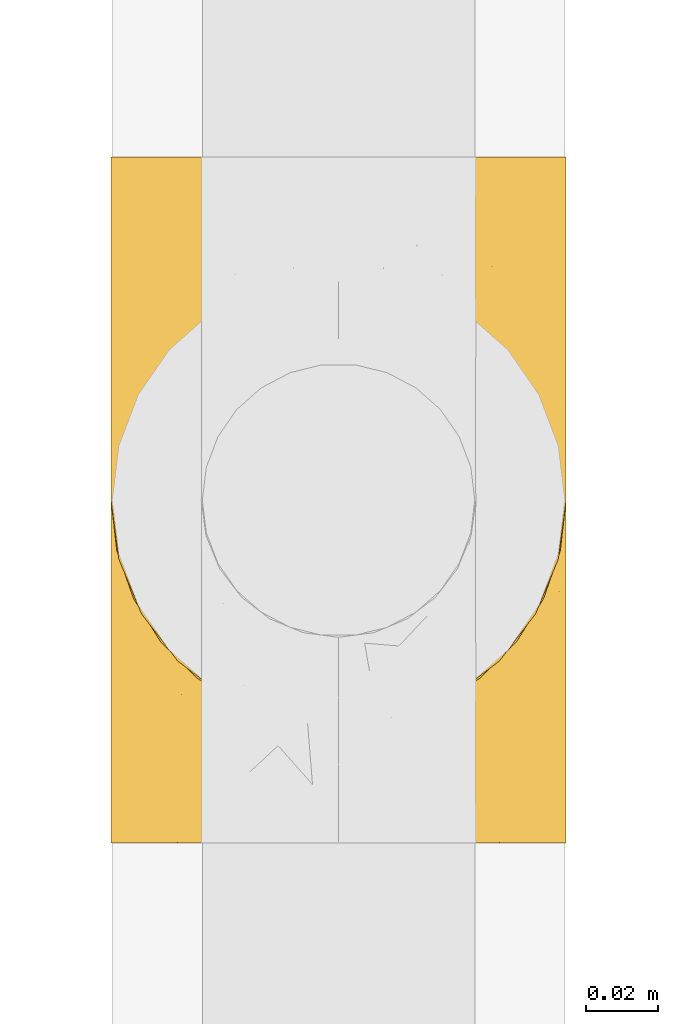
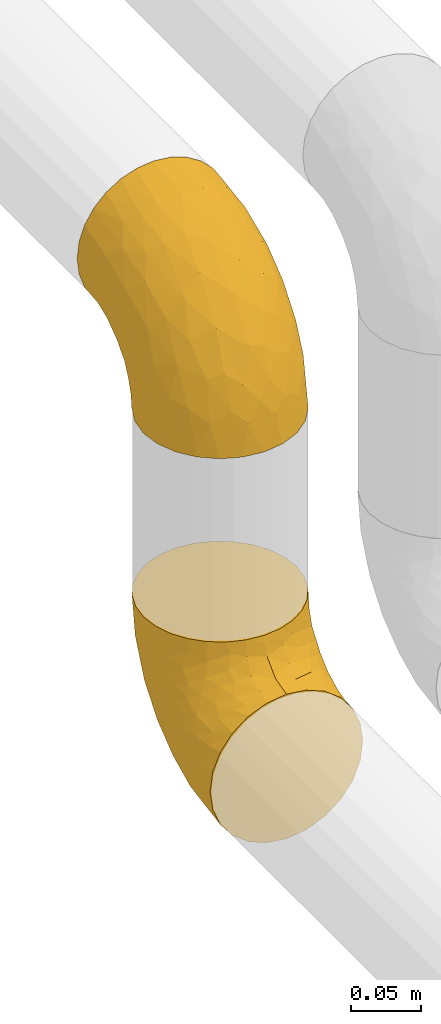
# One storey, part 102 of 827: 2 coverings.
"""IFC2X3 building model written with IfcOpenShell, lengths in millimetres."""

from ifc_helpers import new_model, entity, si_unit, converted_unit, derived_unit, direction, frame, origin, place, context, subcontext, project, spatial, faceted_brep, element, save


model = new_model("IFC2X3")

# Units and contexts
model_context = context("Model", 3, precision=0.01, world=origin(), true_north=direction((6.12303176911189e-17, 1.0)))
body_context = subcontext(model_context, "Body", "Model", "MODEL_VIEW")
ifc_project = project(units=[si_unit("LENGTHUNIT", "METRE", prefix="MILLI"), si_unit("AREAUNIT", "SQUARE_METRE"), si_unit("VOLUMEUNIT", "CUBIC_METRE"), converted_unit("PLANEANGLEUNIT", "DEGREE", entity("IfcRatioMeasure", 0.0174532925199433), si_unit("PLANEANGLEUNIT", "RADIAN"), dimensions=[0, 0, 0, 0, 0, 0, 0]), si_unit("MASSUNIT", "GRAM", prefix="KILO"), derived_unit("MASSDENSITYUNIT", [(si_unit("MASSUNIT", "GRAM", prefix="KILO"), 1), (si_unit("LENGTHUNIT", "METRE"), -3)]), derived_unit("MOMENTOFINERTIAUNIT", [(si_unit("LENGTHUNIT", "METRE"), 4)]), si_unit("TIMEUNIT", "SECOND"), si_unit("FREQUENCYUNIT", "HERTZ"), si_unit("THERMODYNAMICTEMPERATUREUNIT", "DEGREE_CELSIUS"), derived_unit("THERMALTRANSMITTANCEUNIT", [(si_unit("MASSUNIT", "GRAM", prefix="KILO"), 1), (si_unit("THERMODYNAMICTEMPERATUREUNIT", "KELVIN"), -1), (si_unit("TIMEUNIT", "SECOND"), -3)]), derived_unit("VOLUMETRICFLOWRATEUNIT", [(si_unit("LENGTHUNIT", "METRE"), 3), (si_unit("TIMEUNIT", "SECOND"), -1)]), derived_unit("MASSFLOWRATEUNIT", [(si_unit("MASSUNIT", "GRAM", prefix="KILO"), 1), (si_unit("TIMEUNIT", "SECOND"), -1)]), derived_unit("ROTATIONALFREQUENCYUNIT", [(si_unit("TIMEUNIT", "SECOND"), -1)]), si_unit("ELECTRICCURRENTUNIT", "AMPERE"), si_unit("ELECTRICVOLTAGEUNIT", "VOLT"), si_unit("POWERUNIT", "WATT"), si_unit("FORCEUNIT", "NEWTON", prefix="KILO"), si_unit("ILLUMINANCEUNIT", "LUX"), si_unit("LUMINOUSFLUXUNIT", "LUMEN"), si_unit("LUMINOUSINTENSITYUNIT", "CANDELA"), derived_unit("USERDEFINED", [(si_unit("MASSUNIT", "GRAM", prefix="KILO"), -1), (si_unit("LENGTHUNIT", "METRE"), -2), (si_unit("TIMEUNIT", "SECOND"), 3), (si_unit("LUMINOUSFLUXUNIT", "LUMEN"), 1)]), derived_unit("LINEARVELOCITYUNIT", [(si_unit("LENGTHUNIT", "METRE"), 1), (si_unit("TIMEUNIT", "SECOND"), -1)]), si_unit("PRESSUREUNIT", "PASCAL"), derived_unit("USERDEFINED", [(si_unit("LENGTHUNIT", "METRE"), -2), (si_unit("MASSUNIT", "GRAM", prefix="KILO"), 1), (si_unit("TIMEUNIT", "SECOND"), -2)]), derived_unit("LINEARFORCEUNIT", [(si_unit("MASSUNIT", "GRAM", prefix="KILO"), 1), (si_unit("LENGTHUNIT", "METRE"), 1), (si_unit("TIMEUNIT", "SECOND"), -2), (si_unit("LENGTHUNIT", "METRE"), -1)]), derived_unit("PLANARFORCEUNIT", [(si_unit("MASSUNIT", "GRAM", prefix="KILO"), 1), (si_unit("LENGTHUNIT", "METRE"), 1), (si_unit("TIMEUNIT", "SECOND"), -2), (si_unit("LENGTHUNIT", "METRE"), -2)])], contexts=[model_context])

# Site, building, storey
site_placement = place(None, origin())
site = spatial("IfcSite", under=ifc_project, at=site_placement, CompositionType="ELEMENT")
building_placement = place(site_placement, origin())
building = spatial("IfcBuilding", under=site, at=building_placement, CompositionType="ELEMENT")
storey_placement = place(building_placement, frame((0.0, 0.0, 28200.0)))
storey = spatial("IfcBuildingStorey", under=building, at=storey_placement, Name="08", CompositionType="ELEMENT", Elevation=28200.0)

# Coverings
covering_1_placement = place(storey_placement, frame((26598.99, 9529.11, 3035.35)))
element("IfcCovering", 1, at=covering_1_placement, inside=storey, Name=":ADSK_", ObjectType=":ADSK_", PredefinedType="INSULATION", context=body_context, shape_type="Brep", body=[
    faceted_brep([(126.11, 110.62, 159.65), (121.45, 123.95, 159.65), (113.94, 135.9, 159.65), (103.96, 145.89, 159.65), (92.0, 153.4, 159.65), (78.68, 158.06, 159.65), (64.65, 159.65, 159.65), (50.62, 158.06, 159.65), (37.29, 153.4, 159.65), (25.34, 145.89, 159.65), (15.35, 135.91, 159.65), (7.84, 123.95, 159.65), (3.18, 110.63, 159.65), (1.6, 96.6, 159.65), (3.18, 82.57, 159.65), (7.84, 69.24, 159.65), (15.35, 57.29, 159.65), (25.33, 47.3, 159.65), (37.29, 39.79, 159.65), (50.61, 35.13, 159.65), (64.65, 33.55, 159.65), (78.67, 35.13, 159.65), (92.0, 39.79, 159.65), (103.95, 47.3, 159.65), (113.94, 57.28, 159.65), (121.45, 69.24, 159.65), (126.11, 82.56, 159.65), (127.7, 96.6, 159.65), (64.65, 1.6, 127.7), (48.33, 1.6, 125.55), (33.12, 1.6, 119.25), (20.06, 1.6, 109.23), (10.04, 1.6, 96.17), (3.74, 1.6, 80.96), (3.01, 1.6, 75.35), (1.6, 1.6, 64.65), (3.74, 1.6, 48.33), (10.04, 1.6, 33.12), (20.06, 1.6, 20.06), (33.12, 1.6, 10.04), (48.33, 1.6, 3.74), (64.65, 1.6, 1.6), (80.96, 1.6, 3.74), (96.17, 1.6, 10.04), (109.23, 1.6, 20.06), (119.25, 1.6, 33.12), (125.55, 1.6, 48.33), (127.7, 1.6, 64.65), (126.29, 1.6, 75.35), (125.55, 1.6, 80.96), (119.25, 1.6, 96.17), (109.23, 1.6, 109.23), (96.17, 1.6, 119.25), (80.96, 1.6, 125.55), (101.1, 30.13, 16.01), (86.72, 39.4, 10.29), (98.7, 62.65, 24.76), (75.93, 28.52, 4.94), (64.65, 42.5, 6.98), (113.39, 115.57, 87.32), (111.06, 98.94, 62.3), (96.87, 111.29, 58.52), (84.07, 95.5, 36.35), (64.65, 80.62, 22.77), (64.65, 113.35, 47.89), (119.56, 43.71, 40.91), (112.75, 70.76, 42.82), (122.85, 62.71, 57.25), (125.08, 33.16, 51.19), (126.64, 53.41, 66.64), (105.78, 130.65, 98.56), (93.81, 137.68, 94.44), (96.07, 146.84, 123.53), (87.11, 66.58, 20.12), (75.77, 57.7, 12.95), (111.99, 39.88, 28.48), (64.65, 154.26, 118.74), (83.58, 152.07, 121.88), (80.96, 125.54, 65.08), (78.34, 142.81, 92.08), (122.85, 103.99, 98.53), (125.88, 79.4, 81.84), (120.97, 88.81, 72.43), (126.67, 104.86, 134.31), (122.64, 117.38, 129.11), (127.7, 57.43, 82.79), (127.7, 44.19, 76.04), (127.7, 30.95, 69.29), (107.12, 139.96, 129.58), (115.07, 127.03, 115.86), (102.81, 87.17, 42.36), (127.7, 78.45, 103.81), (127.7, 73.2, 98.55), (127.7, 67.94, 93.3), (127.7, 94.63, 147.25), (127.7, 93.29, 138.77), (127.7, 91.95, 130.29), (126.64, 94.6, 107.83), (127.7, 85.2, 117.05), (64.65, 138.47, 80.62), (127.7, 13.99, 66.61), (113.05, 40.46, 121.29), (101.81, 32.36, 128.09), (108.46, 28.71, 118.04), (126.21, 15.53, 79.47), (122.65, 29.06, 94.94), (126.55, 40.03, 86.01), (125.45, 45.36, 94.69), (126.01, 26.46, 83.06), (123.3, 47.56, 104.39), (118.99, 36.28, 107.01), (113.51, 55.57, 148.3), (104.6, 45.02, 143.82), (118.04, 57.55, 134.19), (101.6, 11.56, 116.87), (109.98, 19.2, 111.58), (92.1, 10.07, 122.36), (96.28, 21.04, 124.16), (121.05, 15.52, 94.28), (79.4, 13.84, 128.25), (79.19, 32.67, 146.72), (80.39, 24.86, 134.92), (93.14, 34.31, 138.87), (126.75, 81.47, 133.28), (125.71, 71.26, 121.77), (126.17, 81.64, 145.83), (64.65, 29.26, 143.67), (123.28, 70.65, 139.93), (64.65, 31.93, 153.63), (91.58, 27.99, 132.32), (107.1, 41.71, 132.59), (116.28, 50.14, 126.42), (116.32, 17.57, 102.97), (90.34, 37.62, 149.52), (122.74, 60.48, 120.88), (64.65, 17.57, 131.98), (126.77, 56.96, 96.12), (119.84, 48.98, 115.84), (124.71, 57.29, 108.2), (126.47, 68.25, 110.85), (37.19, 10.07, 122.36), (27.66, 16.58, 118.35), (49.9, 13.84, 128.25), (1.6, 13.99, 66.61), (50.1, 32.67, 146.72), (48.89, 24.86, 134.92), (2.88, 67.81, 110.73), (6.55, 61.09, 121.83), (3.58, 71.26, 121.77), (1.6, 57.43, 82.79), (1.6, 44.19, 76.04), (2.74, 40.03, 86.01), (11.25, 57.55, 134.19), (11.93, 51.01, 124.9), (21.09, 42.79, 132.35), (3.28, 26.46, 83.06), (6.64, 29.06, 94.94), (12.97, 17.57, 102.97), (19.31, 19.2, 111.58), (16.23, 40.46, 121.29), (21.44, 28.84, 118.82), (26.96, 33.48, 128.68), (8.24, 15.52, 94.28), (3.08, 15.53, 79.47), (10.3, 36.28, 107.01), (38.95, 37.62, 149.51), (33.01, 21.04, 124.16), (1.6, 94.63, 147.25), (1.6, 93.29, 138.77), (36.15, 34.31, 138.87), (24.69, 45.03, 143.82), (6.01, 70.65, 139.92), (2.54, 81.47, 133.28), (15.78, 55.58, 148.3), (1.6, 91.95, 130.29), (3.12, 81.64, 145.83), (37.33, 27.86, 131.94), (1.6, 78.45, 103.81), (1.6, 85.2, 117.05), (2.52, 56.96, 96.12), (3.84, 45.36, 94.69), (5.99, 47.57, 104.39), (9.35, 48.27, 114.83), (1.6, 67.94, 93.3), (4.58, 57.3, 108.2), (1.6, 30.95, 69.29), (30.59, 62.65, 24.76), (28.19, 30.13, 16.01), (17.3, 39.88, 28.48), (9.73, 43.71, 40.91), (42.57, 39.4, 10.29), (53.51, 55.79, 12.23), (53.42, 28.41, 4.91), (2.65, 53.41, 66.64), (2.62, 104.86, 134.31), (6.66, 117.39, 129.11), (6.44, 103.99, 98.53), (48.33, 125.54, 65.08), (32.42, 111.29, 58.52), (35.49, 137.69, 94.45), (2.65, 94.6, 107.83), (3.41, 79.4, 81.84), (4.21, 33.16, 51.19), (43.07, 68.78, 20.8), (23.52, 130.66, 98.56), (22.18, 139.97, 129.58), (33.1, 148.6, 131.93), (15.9, 115.58, 87.32), (14.23, 127.03, 115.86), (16.54, 70.76, 42.82), (45.22, 95.5, 36.35), (6.44, 62.71, 57.25), (8.33, 88.81, 72.43), (18.23, 98.94, 62.3), (32.99, 89.09, 38.39), (53.35, 78.72, 22.86), (48.76, 142.21, 92.06), (45.72, 152.07, 121.88)], [[[0, 1, 2, 3, 4, 5, 6, 7, 8, 9, 10, 11, 12, 13, 14, 15, 16, 17, 18, 19, 20, 21, 22, 23, 24, 25, 26, 27]], [[28, 29, 30, 31, 32, 33, 34, 35, 36, 37, 38, 39, 40, 41, 42, 43, 44, 45, 46, 47, 48, 49, 50, 51, 52, 53]], [[54, 55, 56]], [[57, 41, 58]], [[59, 60, 61]], [[62, 63, 64]], [[65, 66, 67]], [[68, 67, 69]], [[70, 71, 72]], [[55, 73, 56]], [[43, 42, 55]], [[55, 74, 73]], [[44, 75, 45]], [[44, 43, 54]], [[76, 5, 77]], [[71, 78, 79]], [[45, 75, 65]], [[46, 68, 47]], [[80, 81, 82]], [[0, 83, 84]], [[69, 85, 86, 87]], [[69, 81, 85]], [[84, 1, 0]], [[2, 88, 3]], [[4, 3, 72]], [[44, 54, 75]], [[5, 4, 77]], [[89, 2, 1]], [[72, 3, 88]], [[5, 76, 6]], [[70, 88, 89]], [[68, 65, 67]], [[88, 2, 89]], [[56, 90, 66]], [[64, 78, 62]], [[81, 91, 92, 93, 85]], [[83, 27, 94, 95, 96]], [[62, 61, 90]], [[97, 96, 98, 91]], [[80, 97, 81]], [[42, 57, 55]], [[62, 78, 61]], [[84, 89, 1]], [[78, 64, 99]], [[57, 74, 55]], [[76, 77, 79]], [[77, 72, 71]], [[82, 81, 67]], [[97, 83, 96]], [[80, 89, 84]], [[79, 78, 99]], [[71, 70, 61]], [[81, 97, 91]], [[83, 80, 84]], [[68, 87, 100, 47]], [[81, 69, 67]], [[68, 69, 87]], [[65, 46, 45]], [[65, 68, 46]], [[66, 65, 75]], [[56, 66, 75]], [[66, 60, 82]], [[71, 61, 78]], [[60, 66, 90]], [[83, 97, 80]], [[27, 83, 0]], [[59, 70, 89]], [[70, 59, 61]], [[89, 80, 59]], [[82, 59, 80]], [[55, 54, 43]], [[75, 54, 56]], [[66, 82, 67]], [[59, 82, 60]], [[41, 57, 42]], [[74, 57, 58]], [[58, 63, 74]], [[62, 74, 63]], [[74, 62, 73]], [[62, 56, 73]], [[4, 72, 77]], [[70, 72, 88]], [[76, 79, 99]], [[71, 79, 77]], [[62, 90, 56]], [[60, 90, 61]], [[101, 102, 103]], [[100, 87, 104]], [[105, 106, 107]], [[108, 104, 87]], [[107, 109, 110]], [[108, 87, 86]], [[111, 112, 113]], [[114, 51, 115]], [[116, 114, 117]], [[51, 50, 118]], [[119, 28, 53]], [[120, 121, 122]], [[98, 123, 124]], [[125, 96, 95]], [[116, 53, 52]], [[126, 121, 120]], [[104, 108, 118]], [[98, 124, 91]], [[25, 24, 127]], [[120, 128, 126]], [[122, 129, 102]], [[95, 94, 27, 26]], [[122, 102, 130]], [[125, 127, 123]], [[24, 111, 127]], [[21, 20, 128]], [[112, 130, 131]], [[48, 47, 100, 49]], [[132, 110, 115]], [[23, 111, 24]], [[129, 119, 117]], [[120, 133, 21]], [[112, 23, 22]], [[134, 113, 131]], [[121, 126, 135]], [[133, 112, 22]], [[128, 120, 21]], [[132, 51, 118]], [[120, 122, 133]], [[119, 121, 135]], [[129, 117, 102]], [[125, 26, 25]], [[26, 125, 95]], [[127, 125, 25]], [[28, 119, 135]], [[119, 53, 116]], [[127, 113, 124]], [[96, 125, 123]], [[112, 131, 113]], [[101, 103, 110]], [[85, 93, 136]], [[124, 123, 127]], [[98, 96, 123]], [[112, 111, 23]], [[127, 111, 113]], [[112, 133, 122]], [[21, 133, 22]], [[107, 110, 105]], [[110, 109, 137]], [[86, 106, 108]], [[138, 109, 136]], [[105, 118, 108]], [[107, 106, 85]], [[104, 50, 49]], [[124, 134, 139]], [[138, 93, 92]], [[92, 91, 139]], [[100, 104, 49]], [[118, 105, 132]], [[104, 118, 50]], [[110, 132, 105]], [[51, 132, 115]], [[108, 106, 105]], [[85, 106, 86]], [[114, 116, 52]], [[119, 116, 117]], [[51, 114, 52]], [[114, 115, 103]], [[117, 114, 103]], [[130, 102, 101]], [[117, 103, 102]], [[110, 103, 115]], [[130, 101, 131]], [[122, 130, 112]], [[101, 137, 131]], [[113, 134, 124]], [[137, 134, 131]], [[124, 139, 91]], [[134, 138, 139]], [[92, 139, 138]], [[110, 137, 101]], [[134, 137, 138]], [[136, 109, 107]], [[137, 109, 138]], [[85, 136, 107]], [[138, 136, 93]], [[122, 121, 129]], [[129, 121, 119]], [[30, 140, 141]], [[30, 29, 140]], [[28, 135, 142]], [[143, 35, 34, 33]], [[19, 144, 128]], [[126, 145, 135]], [[146, 147, 148]], [[149, 150, 151]], [[152, 153, 154]], [[155, 156, 151]], [[157, 31, 158]], [[159, 160, 161]], [[32, 162, 163]], [[158, 31, 30]], [[157, 164, 156]], [[126, 144, 145]], [[126, 128, 144]], [[18, 165, 19]], [[141, 166, 160]], [[14, 13, 167, 168]], [[163, 143, 33]], [[169, 165, 170]], [[18, 17, 170]], [[153, 159, 154]], [[142, 135, 145]], [[148, 171, 172]], [[159, 161, 154]], [[171, 152, 173]], [[173, 17, 16]], [[16, 15, 171]], [[158, 160, 164]], [[174, 175, 168]], [[173, 170, 17]], [[19, 128, 20]], [[174, 172, 175]], [[165, 169, 144]], [[162, 157, 156]], [[175, 172, 171]], [[144, 169, 145]], [[176, 169, 161]], [[166, 140, 142]], [[175, 171, 15]], [[168, 175, 14]], [[14, 175, 15]], [[142, 145, 176]], [[28, 142, 29]], [[148, 177, 146]], [[148, 178, 177]], [[152, 171, 148]], [[179, 180, 181]], [[164, 180, 156]], [[174, 178, 172]], [[148, 172, 178]], [[171, 173, 16]], [[170, 173, 152]], [[19, 165, 144]], [[170, 165, 18]], [[153, 182, 159]], [[146, 183, 184]], [[181, 180, 164]], [[180, 151, 156]], [[163, 155, 185]], [[155, 150, 185]], [[162, 156, 155]], [[143, 163, 185]], [[180, 179, 149]], [[32, 163, 33]], [[163, 162, 155]], [[31, 162, 32]], [[31, 157, 162]], [[164, 157, 158]], [[149, 151, 180]], [[155, 151, 150]], [[142, 140, 29]], [[141, 140, 166]], [[176, 145, 169]], [[30, 141, 158]], [[164, 160, 159]], [[158, 141, 160]], [[166, 161, 160]], [[154, 169, 170]], [[169, 154, 161]], [[152, 154, 170]], [[147, 152, 148]], [[153, 147, 182]], [[181, 182, 184]], [[164, 159, 182]], [[161, 166, 176]], [[142, 176, 166]], [[183, 146, 177]], [[184, 182, 147]], [[184, 147, 146]], [[152, 147, 153]], [[182, 181, 164]], [[179, 184, 183]], [[184, 179, 181]], [[149, 179, 183]], [[186, 187, 188]], [[37, 36, 189]], [[190, 191, 192]], [[193, 185, 150, 149]], [[194, 195, 196]], [[197, 198, 199]], [[200, 201, 177]], [[193, 202, 185]], [[203, 190, 186]], [[202, 189, 36]], [[41, 40, 192]], [[204, 205, 199]], [[9, 8, 206]], [[187, 190, 39]], [[40, 39, 190]], [[38, 37, 188]], [[207, 208, 204]], [[202, 35, 143, 185]], [[39, 38, 187]], [[195, 11, 208]], [[201, 149, 183, 177]], [[188, 189, 209]], [[197, 64, 210]], [[186, 188, 209]], [[13, 12, 194]], [[211, 201, 212]], [[12, 11, 195]], [[193, 201, 211]], [[212, 201, 196]], [[10, 208, 11]], [[213, 214, 209]], [[64, 63, 215]], [[216, 197, 199]], [[8, 217, 206]], [[7, 217, 8]], [[203, 191, 190]], [[7, 6, 76]], [[208, 205, 204]], [[205, 10, 9]], [[199, 205, 206]], [[7, 76, 217]], [[205, 208, 10]], [[216, 76, 99]], [[200, 177, 178, 174]], [[64, 197, 99]], [[63, 58, 191]], [[208, 196, 195]], [[196, 200, 194]], [[198, 197, 210]], [[216, 199, 217]], [[201, 193, 149]], [[202, 193, 211]], [[202, 211, 189]], [[35, 202, 36]], [[211, 212, 209]], [[37, 189, 188]], [[211, 209, 189]], [[213, 198, 214]], [[200, 174, 194]], [[201, 200, 196]], [[214, 198, 210]], [[213, 207, 198]], [[194, 174, 168, 167, 13]], [[195, 194, 12]], [[198, 204, 199]], [[204, 198, 207]], [[212, 207, 213]], [[196, 208, 207]], [[188, 187, 38]], [[190, 187, 186]], [[207, 212, 196]], [[209, 212, 213]], [[214, 203, 186]], [[191, 215, 63]], [[191, 203, 215]], [[192, 191, 58]], [[41, 192, 58]], [[190, 192, 40]], [[203, 210, 215]], [[64, 215, 210]], [[199, 206, 217]], [[9, 206, 205]], [[76, 216, 217]], [[99, 197, 216]], [[203, 214, 210]], [[209, 214, 186]]]),
])
covering_2_placement = place(storey_placement, frame((26598.99, 9561.06, 3353.4)))
element("IfcCovering", 2, at=covering_2_placement, inside=storey, Name=":ADSK_", ObjectType=":ADSK_", PredefinedType="INSULATION", context=body_context, shape_type="Brep", body=[
    faceted_brep([(3.18, 159.65, 110.62), (7.84, 159.65, 123.95), (15.35, 159.65, 135.9), (25.33, 159.65, 145.89), (37.29, 159.65, 153.4), (50.61, 159.65, 158.06), (64.65, 159.65, 159.65), (78.67, 159.65, 158.06), (92.0, 159.65, 153.4), (103.95, 159.65, 145.89), (113.94, 159.65, 135.91), (121.45, 159.65, 123.95), (126.11, 159.65, 110.63), (127.7, 159.65, 96.6), (126.11, 159.65, 82.57), (121.45, 159.65, 69.24), (113.94, 159.65, 57.29), (103.96, 159.65, 47.3), (92.0, 159.65, 39.79), (78.68, 159.65, 35.13), (64.65, 159.65, 33.55), (50.62, 159.65, 35.13), (37.29, 159.65, 39.79), (25.34, 159.65, 47.3), (15.35, 159.65, 57.28), (7.84, 159.65, 69.24), (3.18, 159.65, 82.56), (1.6, 159.65, 96.6), (64.65, 127.7, 1.6), (80.96, 125.55, 1.6), (96.17, 119.25, 1.6), (109.23, 109.23, 1.6), (119.25, 96.17, 1.6), (125.55, 80.96, 1.6), (126.29, 75.35, 1.6), (127.7, 64.65, 1.6), (125.55, 48.33, 1.6), (119.25, 33.12, 1.6), (109.23, 20.06, 1.6), (96.17, 10.04, 1.6), (80.96, 3.74, 1.6), (64.65, 1.6, 1.6), (48.33, 3.74, 1.6), (33.12, 10.04, 1.6), (20.06, 20.06, 1.6), (10.04, 33.12, 1.6), (3.74, 48.33, 1.6), (1.6, 64.65, 1.6), (3.01, 75.35, 1.6), (3.74, 80.96, 1.6), (10.04, 96.17, 1.6), (20.06, 109.23, 1.6), (33.12, 119.25, 1.6), (48.33, 125.55, 1.6), (28.19, 16.01, 30.13), (42.57, 10.29, 39.4), (30.59, 24.76, 62.65), (53.36, 4.94, 28.52), (64.65, 6.98, 42.5), (15.9, 87.32, 115.57), (18.23, 62.3, 98.94), (32.42, 58.52, 111.29), (45.22, 36.35, 95.5), (64.65, 22.77, 80.62), (64.65, 47.89, 113.35), (9.73, 40.91, 43.71), (16.54, 42.82, 70.76), (6.44, 57.25, 62.71), (4.21, 51.19, 33.16), (2.65, 66.64, 53.41), (23.51, 98.56, 130.65), (35.48, 94.44, 137.68), (33.22, 123.53, 146.84), (42.18, 20.12, 66.58), (53.52, 12.95, 57.7), (17.3, 28.48, 39.88), (64.65, 118.74, 154.26), (45.71, 121.88, 152.07), (48.33, 65.08, 125.54), (50.95, 92.08, 142.81), (6.44, 98.53, 103.99), (3.41, 81.84, 79.4), (8.33, 72.43, 88.81), (2.62, 134.31, 104.86), (6.65, 129.11, 117.38), (1.6, 82.79, 57.43), (1.6, 76.04, 44.19), (1.6, 69.29, 30.95), (22.17, 129.58, 139.96), (14.22, 115.86, 127.03), (26.48, 42.36, 87.17), (1.6, 103.81, 78.45), (1.6, 98.55, 73.2), (1.6, 93.3, 67.94), (1.6, 147.25, 94.63), (1.6, 138.77, 93.29), (1.6, 130.29, 91.95), (2.65, 107.83, 94.6), (1.6, 117.05, 85.2), (64.65, 80.62, 138.47), (1.6, 66.61, 13.99), (16.24, 121.29, 40.46), (27.48, 128.09, 32.36), (20.83, 118.04, 28.71), (3.08, 79.47, 15.53), (6.64, 94.94, 29.06), (2.74, 86.01, 40.03), (3.84, 94.69, 45.36), (3.28, 83.06, 26.46), (5.99, 104.39, 47.56), (10.3, 107.01, 36.28), (15.78, 148.3, 55.57), (24.69, 143.82, 45.02), (11.25, 134.19, 57.55), (27.69, 116.87, 11.56), (19.31, 111.58, 19.2), (37.19, 122.36, 10.07), (33.01, 124.16, 21.04), (8.24, 94.28, 15.52), (49.89, 128.25, 13.84), (50.1, 146.72, 32.67), (48.9, 134.92, 24.86), (36.15, 138.87, 34.31), (2.54, 133.28, 81.47), (3.58, 121.77, 71.26), (3.12, 145.83, 81.64), (64.65, 143.67, 29.26), (6.01, 139.93, 70.65), (64.65, 153.63, 31.93), (37.71, 132.32, 27.99), (22.19, 132.59, 41.71), (13.01, 126.42, 50.14), (12.97, 102.97, 17.57), (38.95, 149.52, 37.62), (6.55, 120.88, 60.48), (64.65, 131.98, 17.57), (2.52, 96.12, 56.96), (9.45, 115.84, 48.98), (4.58, 108.2, 57.29), (2.83, 110.85, 68.25), (92.1, 122.36, 10.07), (101.63, 118.35, 16.58), (79.39, 128.25, 13.84), (127.7, 66.61, 13.99), (79.2, 146.72, 32.67), (80.4, 134.92, 24.86), (126.41, 110.73, 67.81), (122.74, 121.83, 61.09), (125.71, 121.77, 71.26), (127.7, 82.79, 57.43), (127.7, 76.04, 44.19), (126.55, 86.01, 40.03), (118.04, 134.19, 57.55), (117.36, 124.9, 51.01), (108.2, 132.35, 42.79), (126.01, 83.06, 26.46), (122.65, 94.94, 29.06), (116.32, 102.97, 17.57), (109.98, 111.58, 19.2), (113.06, 121.29, 40.46), (107.85, 118.82, 28.84), (102.33, 128.68, 33.48), (121.05, 94.28, 15.52), (126.21, 79.47, 15.53), (118.99, 107.01, 36.28), (90.34, 149.51, 37.62), (96.28, 124.16, 21.04), (127.7, 147.25, 94.63), (127.7, 138.77, 93.29), (93.14, 138.87, 34.31), (104.6, 143.82, 45.03), (123.28, 139.92, 70.65), (126.75, 133.28, 81.47), (113.51, 148.3, 55.58), (127.7, 130.29, 91.95), (126.17, 145.83, 81.64), (91.96, 131.94, 27.86), (127.7, 103.81, 78.45), (127.7, 117.05, 85.2), (126.77, 96.12, 56.96), (125.45, 94.69, 45.36), (123.3, 104.39, 47.57), (119.94, 114.83, 48.27), (127.7, 93.3, 67.94), (124.71, 108.2, 57.3), (127.7, 69.29, 30.95), (98.7, 24.76, 62.65), (101.1, 16.01, 30.13), (111.99, 28.48, 39.88), (119.56, 40.91, 43.71), (86.72, 10.29, 39.4), (75.78, 12.23, 55.79), (75.87, 4.91, 28.41), (126.64, 66.64, 53.41), (126.67, 134.31, 104.86), (122.63, 129.11, 117.39), (122.85, 98.53, 103.99), (80.96, 65.08, 125.54), (96.87, 58.52, 111.29), (93.81, 94.45, 137.69), (126.64, 107.83, 94.6), (125.88, 81.84, 79.4), (125.08, 51.19, 33.16), (86.22, 20.8, 68.78), (105.77, 98.56, 130.66), (107.12, 129.58, 139.97), (96.19, 131.93, 148.6), (113.39, 87.32, 115.58), (115.06, 115.86, 127.03), (112.75, 42.82, 70.76), (84.07, 36.35, 95.5), (122.85, 57.25, 62.71), (120.97, 72.43, 88.81), (111.06, 62.3, 98.94), (96.3, 38.39, 89.09), (75.94, 22.86, 78.72), (80.53, 92.06, 142.21), (83.57, 121.88, 152.07)], [[[0, 1, 2, 3, 4, 5, 6, 7, 8, 9, 10, 11, 12, 13, 14, 15, 16, 17, 18, 19, 20, 21, 22, 23, 24, 25, 26, 27]], [[28, 29, 30, 31, 32, 33, 34, 35, 36, 37, 38, 39, 40, 41, 42, 43, 44, 45, 46, 47, 48, 49, 50, 51, 52, 53]], [[54, 55, 56]], [[57, 41, 58]], [[59, 60, 61]], [[62, 63, 64]], [[65, 66, 67]], [[68, 67, 69]], [[70, 71, 72]], [[55, 73, 56]], [[43, 42, 55]], [[55, 74, 73]], [[44, 75, 45]], [[44, 43, 54]], [[76, 5, 77]], [[71, 78, 79]], [[45, 75, 65]], [[46, 68, 47]], [[80, 81, 82]], [[0, 83, 84]], [[69, 85, 86, 87]], [[69, 81, 85]], [[84, 1, 0]], [[2, 88, 3]], [[4, 3, 72]], [[44, 54, 75]], [[5, 4, 77]], [[89, 2, 1]], [[72, 3, 88]], [[5, 76, 6]], [[70, 88, 89]], [[68, 65, 67]], [[88, 2, 89]], [[56, 90, 66]], [[64, 78, 62]], [[81, 91, 92, 93, 85]], [[83, 27, 94, 95, 96]], [[62, 61, 90]], [[97, 96, 98, 91]], [[80, 97, 81]], [[42, 57, 55]], [[62, 78, 61]], [[84, 89, 1]], [[78, 64, 99]], [[57, 74, 55]], [[76, 77, 79]], [[77, 72, 71]], [[82, 81, 67]], [[97, 83, 96]], [[80, 89, 84]], [[79, 78, 99]], [[71, 70, 61]], [[81, 97, 91]], [[83, 80, 84]], [[68, 87, 100, 47]], [[81, 69, 67]], [[68, 69, 87]], [[65, 46, 45]], [[65, 68, 46]], [[66, 65, 75]], [[56, 66, 75]], [[66, 60, 82]], [[71, 61, 78]], [[60, 66, 90]], [[83, 97, 80]], [[27, 83, 0]], [[59, 70, 89]], [[70, 59, 61]], [[89, 80, 59]], [[82, 59, 80]], [[55, 54, 43]], [[75, 54, 56]], [[66, 82, 67]], [[59, 82, 60]], [[41, 57, 42]], [[74, 57, 58]], [[58, 63, 74]], [[62, 74, 63]], [[74, 62, 73]], [[62, 56, 73]], [[4, 72, 77]], [[70, 72, 88]], [[76, 79, 99]], [[71, 79, 77]], [[62, 90, 56]], [[60, 90, 61]], [[101, 102, 103]], [[100, 87, 104]], [[105, 106, 107]], [[108, 104, 87]], [[107, 109, 110]], [[108, 87, 86]], [[111, 112, 113]], [[114, 51, 115]], [[116, 114, 117]], [[51, 50, 118]], [[119, 28, 53]], [[120, 121, 122]], [[98, 123, 124]], [[125, 96, 95]], [[116, 53, 52]], [[126, 121, 120]], [[104, 108, 118]], [[98, 124, 91]], [[25, 24, 127]], [[120, 128, 126]], [[122, 129, 102]], [[95, 94, 27, 26]], [[122, 102, 130]], [[125, 127, 123]], [[24, 111, 127]], [[21, 20, 128]], [[112, 130, 131]], [[48, 47, 100, 49]], [[132, 110, 115]], [[23, 111, 24]], [[129, 119, 117]], [[120, 133, 21]], [[112, 23, 22]], [[134, 113, 131]], [[121, 126, 135]], [[133, 112, 22]], [[128, 120, 21]], [[132, 51, 118]], [[120, 122, 133]], [[119, 121, 135]], [[129, 117, 102]], [[125, 26, 25]], [[26, 125, 95]], [[127, 125, 25]], [[28, 119, 135]], [[119, 53, 116]], [[127, 113, 124]], [[96, 125, 123]], [[112, 131, 113]], [[101, 103, 110]], [[85, 93, 136]], [[124, 123, 127]], [[98, 96, 123]], [[112, 111, 23]], [[127, 111, 113]], [[112, 133, 122]], [[21, 133, 22]], [[107, 110, 105]], [[110, 109, 137]], [[86, 106, 108]], [[138, 109, 136]], [[105, 118, 108]], [[107, 106, 85]], [[104, 50, 49]], [[124, 134, 139]], [[138, 93, 92]], [[92, 91, 139]], [[100, 104, 49]], [[118, 105, 132]], [[104, 118, 50]], [[110, 132, 105]], [[51, 132, 115]], [[108, 106, 105]], [[85, 106, 86]], [[114, 116, 52]], [[119, 116, 117]], [[51, 114, 52]], [[114, 115, 103]], [[117, 114, 103]], [[130, 102, 101]], [[117, 103, 102]], [[110, 103, 115]], [[130, 101, 131]], [[122, 130, 112]], [[101, 137, 131]], [[113, 134, 124]], [[137, 134, 131]], [[124, 139, 91]], [[134, 138, 139]], [[92, 139, 138]], [[110, 137, 101]], [[134, 137, 138]], [[136, 109, 107]], [[137, 109, 138]], [[85, 136, 107]], [[138, 136, 93]], [[122, 121, 129]], [[129, 121, 119]], [[30, 140, 141]], [[30, 29, 140]], [[28, 135, 142]], [[143, 35, 34, 33]], [[19, 144, 128]], [[126, 145, 135]], [[146, 147, 148]], [[149, 150, 151]], [[152, 153, 154]], [[155, 156, 151]], [[157, 31, 158]], [[159, 160, 161]], [[32, 162, 163]], [[158, 31, 30]], [[157, 164, 156]], [[126, 144, 145]], [[126, 128, 144]], [[18, 165, 19]], [[141, 166, 160]], [[14, 13, 167, 168]], [[163, 143, 33]], [[169, 165, 170]], [[18, 17, 170]], [[153, 159, 154]], [[142, 135, 145]], [[148, 171, 172]], [[159, 161, 154]], [[171, 152, 173]], [[173, 17, 16]], [[16, 15, 171]], [[158, 160, 164]], [[174, 175, 168]], [[173, 170, 17]], [[19, 128, 20]], [[174, 172, 175]], [[165, 169, 144]], [[162, 157, 156]], [[175, 172, 171]], [[144, 169, 145]], [[176, 169, 161]], [[166, 140, 142]], [[175, 171, 15]], [[168, 175, 14]], [[14, 175, 15]], [[142, 145, 176]], [[28, 142, 29]], [[148, 177, 146]], [[148, 178, 177]], [[152, 171, 148]], [[179, 180, 181]], [[164, 180, 156]], [[174, 178, 172]], [[148, 172, 178]], [[171, 173, 16]], [[170, 173, 152]], [[19, 165, 144]], [[170, 165, 18]], [[153, 182, 159]], [[146, 183, 184]], [[181, 180, 164]], [[180, 151, 156]], [[163, 155, 185]], [[155, 150, 185]], [[162, 156, 155]], [[143, 163, 185]], [[180, 179, 149]], [[32, 163, 33]], [[163, 162, 155]], [[31, 162, 32]], [[31, 157, 162]], [[164, 157, 158]], [[149, 151, 180]], [[155, 151, 150]], [[142, 140, 29]], [[141, 140, 166]], [[176, 145, 169]], [[30, 141, 158]], [[164, 160, 159]], [[158, 141, 160]], [[166, 161, 160]], [[154, 169, 170]], [[169, 154, 161]], [[152, 154, 170]], [[147, 152, 148]], [[153, 147, 182]], [[181, 182, 184]], [[164, 159, 182]], [[161, 166, 176]], [[142, 176, 166]], [[183, 146, 177]], [[184, 182, 147]], [[184, 147, 146]], [[152, 147, 153]], [[182, 181, 164]], [[179, 184, 183]], [[184, 179, 181]], [[149, 179, 183]], [[186, 187, 188]], [[37, 36, 189]], [[190, 191, 192]], [[193, 185, 150, 149]], [[194, 195, 196]], [[197, 198, 199]], [[200, 201, 177]], [[193, 202, 185]], [[203, 190, 186]], [[202, 189, 36]], [[41, 40, 192]], [[204, 205, 199]], [[9, 8, 206]], [[187, 190, 39]], [[40, 39, 190]], [[38, 37, 188]], [[207, 208, 204]], [[202, 35, 143, 185]], [[39, 38, 187]], [[195, 11, 208]], [[201, 149, 183, 177]], [[188, 189, 209]], [[197, 64, 210]], [[186, 188, 209]], [[13, 12, 194]], [[211, 201, 212]], [[12, 11, 195]], [[193, 201, 211]], [[212, 201, 196]], [[10, 208, 11]], [[213, 214, 209]], [[64, 63, 215]], [[216, 197, 199]], [[8, 217, 206]], [[7, 217, 8]], [[203, 191, 190]], [[7, 6, 76]], [[208, 205, 204]], [[205, 10, 9]], [[199, 205, 206]], [[7, 76, 217]], [[205, 208, 10]], [[216, 76, 99]], [[200, 177, 178, 174]], [[64, 197, 99]], [[63, 58, 191]], [[208, 196, 195]], [[196, 200, 194]], [[198, 197, 210]], [[216, 199, 217]], [[201, 193, 149]], [[202, 193, 211]], [[202, 211, 189]], [[35, 202, 36]], [[211, 212, 209]], [[37, 189, 188]], [[211, 209, 189]], [[213, 198, 214]], [[200, 174, 194]], [[201, 200, 196]], [[214, 198, 210]], [[213, 207, 198]], [[194, 174, 168, 167, 13]], [[195, 194, 12]], [[198, 204, 199]], [[204, 198, 207]], [[212, 207, 213]], [[196, 208, 207]], [[188, 187, 38]], [[190, 187, 186]], [[207, 212, 196]], [[209, 212, 213]], [[214, 203, 186]], [[191, 215, 63]], [[191, 203, 215]], [[192, 191, 58]], [[41, 192, 58]], [[190, 192, 40]], [[203, 210, 215]], [[64, 215, 210]], [[199, 206, 217]], [[9, 206, 205]], [[76, 216, 217]], [[99, 197, 216]], [[203, 214, 210]], [[209, 214, 186]]]),
])

save(model, "model.ifc")
